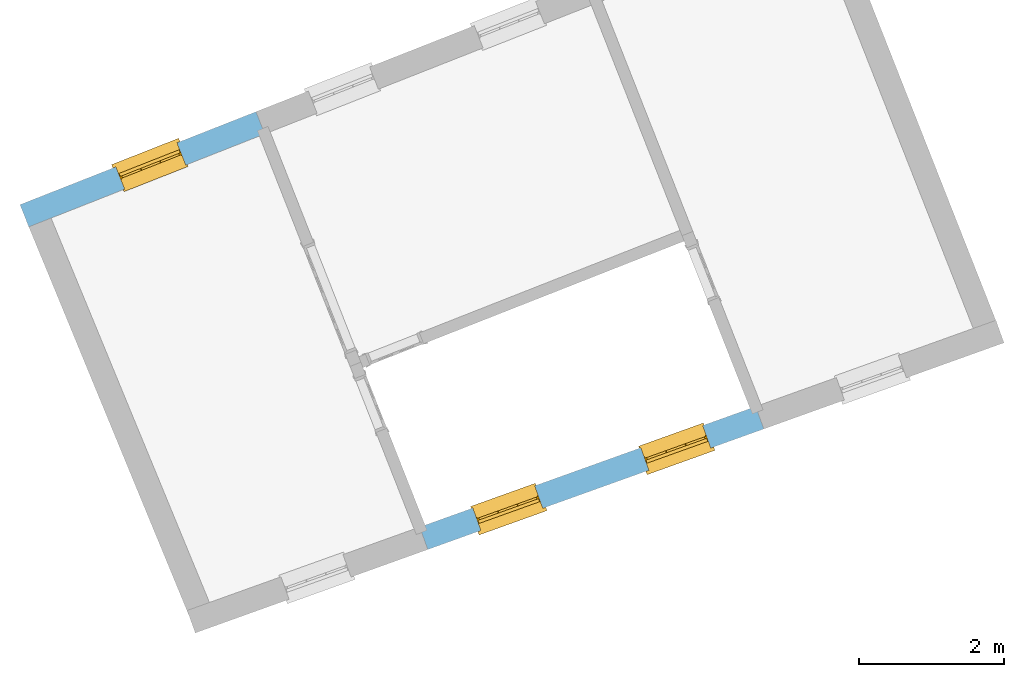
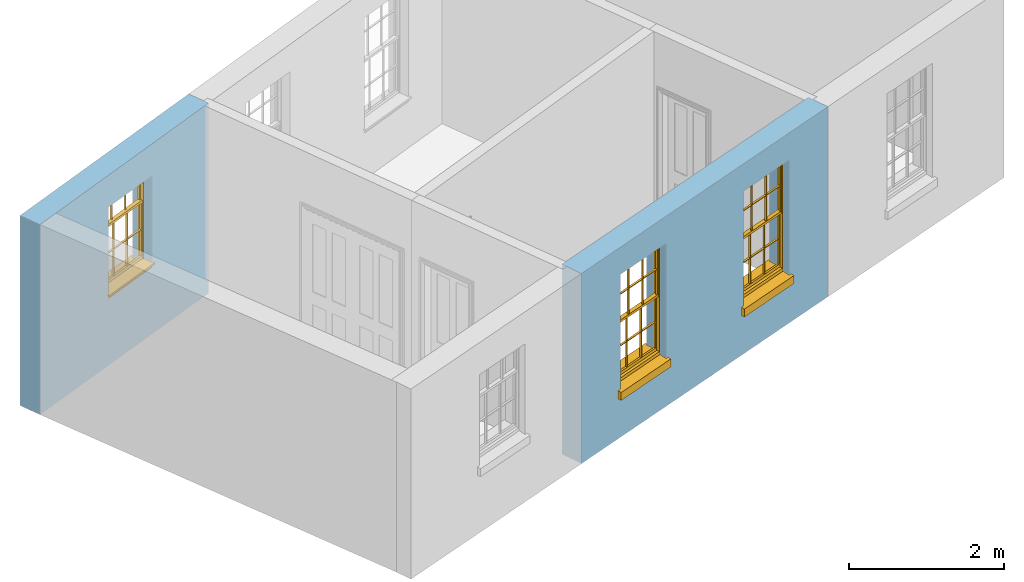
# One storey, part 4 of 6: 3 windows, 3 openings, plus 2 elements that do not belong to this part.
"""IFC2X3 building model written with IfcOpenShell, lengths in metres."""

import ifcopenshell
import ifcopenshell.guid

model = None  # the IFC model being written
_history = None  # IfcOwnerHistory: only IFC2X3 demands one
_inside = {}  # id of a spatial element -> (the spatial element, [elements in it])
_under = {}  # id of a project, library or spatial element -> (it, [spatial elements below it])
_declared = {}  # id of a project -> (the project, [libraries it declares])
_typed = {}  # id of a type object -> (the type object, [elements of that type])
_made_of = {}  # id of a material, layer set ... -> (it, [elements and type objects made of it])


def new_model(schema):
    """Start an empty IFC model of exactly this schema.

    Asked for "IFC4X3", IfcOpenShell would pick the latest addendum, in which some entities
    have other attributes; the version numbers below select the first issue.
    IFC2X3 requires an IfcOwnerHistory on every rooted entity: one is made here for all.
    """
    global model, _history
    if schema == "IFC4X3":
        model = ifcopenshell.file(schema_version=(4, 3, 0, 0))
    else:
        model = ifcopenshell.file(schema=schema)
    _inside.clear()
    _under.clear()
    _declared.clear()
    _typed.clear()
    _made_of.clear()
    _history = None
    if model.schema == "IFC2X3":
        org = make("IfcOrganization", Name="unknown")
        user = make(
            "IfcPersonAndOrganization",
            ThePerson=make("IfcPerson", FamilyName="unknown"),
            TheOrganization=org,
        )
        app = make(
            "IfcApplication",
            ApplicationDeveloper=org,
            Version="unknown",
            ApplicationFullName="unknown",
            ApplicationIdentifier="unknown",
        )
        _history = make(
            "IfcOwnerHistory",
            OwningUser=user,
            OwningApplication=app,
            ChangeAction="ADDED",
            CreationDate=0,
        )
    return model


def make(cls, **values):
    """One entity of the class cls with the attributes given. An attribute that is None is left unset."""
    return model.create_entity(
        cls, **{name: value for name, value in values.items() if value is not None}
    )


def rooted(cls, **values):
    """An entity with a GlobalId (a new one), such as an element, a storey or a relation."""
    return make(cls, GlobalId=ifcopenshell.guid.new(), OwnerHistory=_history, **values)


def si_unit(unit_type, name, prefix=None):
    """IfcSIUnit, for example si_unit("LENGTHUNIT", "METRE", prefix="MILLI")."""
    return make("IfcSIUnit", UnitType=unit_type, Prefix=prefix, Name=name)


def assignment(units):
    """IfcUnitAssignment: the units of a project."""
    return None if units is None else make("IfcUnitAssignment", Units=units)


def point(xyz):
    """IfcCartesianPoint."""
    return None if xyz is None else make("IfcCartesianPoint", Coordinates=xyz)


def direction(xyz):
    """IfcDirection."""
    return None if xyz is None else make("IfcDirection", DirectionRatios=xyz)


def frame(location, z_axis=None, x_axis=None):
    """IfcAxis2Placement3D, a coordinate frame: its origin and axes. An axis left out is left unset."""
    return make(
        "IfcAxis2Placement3D",
        Location=point(location),
        Axis=direction(z_axis),
        RefDirection=direction(x_axis),
    )


def origin():
    """The frame at (0, 0, 0) with its axes left unset."""
    return frame((0.0, 0.0, 0.0))


def place(relative_to, where):
    """IfcLocalPlacement: puts the frame where relative to a parent placement (None: the world)."""
    return make(
        "IfcLocalPlacement", PlacementRelTo=relative_to, RelativePlacement=where
    )


def context(
    kind, dimensions, precision=None, world=None, true_north=None, identifier=None
):
    """IfcGeometricRepresentationContext, for example the 3D "Model" context."""
    return make(
        "IfcGeometricRepresentationContext",
        ContextIdentifier=identifier,
        ContextType=kind,
        CoordinateSpaceDimension=dimensions,
        Precision=precision,
        WorldCoordinateSystem=world,
        TrueNorth=true_north,
    )


def subcontext(parent, identifier, kind, view, scale=None):
    """IfcGeometricRepresentationSubContext, for example "Body" below "Model"."""
    return make(
        "IfcGeometricRepresentationSubContext",
        ContextIdentifier=identifier,
        ContextType=kind,
        ParentContext=parent,
        TargetScale=scale,
        TargetView=view,
    )


def project(units=None, contexts=None):
    """IfcProject with its units and contexts."""
    return rooted(
        "IfcProject",
        Name="project",
        RepresentationContexts=contexts,
        UnitsInContext=assignment(units),
    )


def spatial(cls, under=None, at=None, **own):
    """A site, building, storey or space (cls), placed at a placement, below another one or the project."""
    s = rooted(cls, ObjectPlacement=at, **own)
    if under is not None:
        _under.setdefault(under.id(), (under, []))[1].append(s)
    return s


def polyline(points):
    """IfcPolyline through the points."""
    return make("IfcPolyline", Points=[point(p) for p in points])


def outline(outer, holes=None, kind="AREA"):
    """IfcArbitraryClosedProfileDef: a profile drawn as a closed curve; with holes, ...WithVoids."""
    if holes is None:
        return make("IfcArbitraryClosedProfileDef", ProfileType=kind, OuterCurve=outer)
    return make(
        "IfcArbitraryProfileDefWithVoids",
        ProfileType=kind,
        OuterCurve=outer,
        InnerCurves=holes,
    )


def extrude(swept, where, along, depth):
    """IfcExtrudedAreaSolid: the profile swept, set in the frame where, extruded along a direction by depth."""
    return make(
        "IfcExtrudedAreaSolid",
        SweptArea=swept,
        Position=where,
        ExtrudedDirection=direction(along),
        Depth=depth,
    )


def faces_of(points, faces, orient=None, outer=None):
    """IfcFace entities. A face is a list of loops; a loop is a list of indices into points, from 0.

    orient and outer hold one flag for each loop. By default every Orientation is true, the
    first loop of a face is its IfcFaceOuterBound and the others are IfcFaceBound.
    """
    made = []
    for i, loops in enumerate(faces):
        bounds = []
        for j, loop in enumerate(loops):
            is_outer = j == 0 if outer is None else outer[i][j]
            bounds.append(
                make(
                    "IfcFaceOuterBound" if is_outer else "IfcFaceBound",
                    Bound=make("IfcPolyLoop", Polygon=[points[k] for k in loop]),
                    Orientation=True if orient is None else orient[i][j],
                )
            )
        made.append(make("IfcFace", Bounds=bounds))
    return made


def faceted_brep(points, faces, orient=None, outer=None, voids=None):
    """IfcFacetedBrep: a solid bounded by flat faces; with voids (closed shells), ...WithVoids."""
    shared = [point(p) for p in points]
    hull = make("IfcClosedShell", CfsFaces=faces_of(shared, faces, orient, outer))
    if voids is None:
        return make("IfcFacetedBrep", Outer=hull)
    return make(
        "IfcFacetedBrepWithVoids",
        Outer=hull,
        Voids=[
            make(cls, CfsFaces=faces_of(shared, fs, o, b)) for cls, fs, o, b in voids
        ],
    )


def shape(context_of_items, identifier, shape_type, items):
    """IfcShapeRepresentation: the items that make up one representation, for example the "Body"."""
    return make(
        "IfcShapeRepresentation",
        ContextOfItems=context_of_items,
        RepresentationIdentifier=identifier,
        RepresentationType=shape_type,
        Items=items,
    )


def material(Name=None, Category=None):
    """IfcMaterial."""
    return make("IfcMaterial", Name=Name, Category=Category)


def layer(
    of_material, thickness, ventilated=None, Name=None, Category=None, Priority=None
):
    """IfcMaterialLayer: one layer of a wall or slab, of a material (None: an air gap)."""
    return make(
        "IfcMaterialLayer",
        Material=of_material,
        LayerThickness=thickness,
        IsVentilated=ventilated,
        Name=Name,
        Category=Category,
        Priority=Priority,
    )


def layer_set(layers, Name=None):
    """IfcMaterialLayerSet."""
    return make("IfcMaterialLayerSet", MaterialLayers=layers, LayerSetName=Name)


def layer_usage(for_layer_set, set_direction, sense, offset, extent=None):
    """IfcMaterialLayerSetUsage: how a layer set lies in its element."""
    return make(
        "IfcMaterialLayerSetUsage",
        ForLayerSet=for_layer_set,
        LayerSetDirection=set_direction,
        DirectionSense=sense,
        OffsetFromReferenceLine=offset,
        ReferenceExtent=extent,
    )


def made_of(thing, what):
    """Note that an element or type object is made of a material, layer set ...; save() writes the relation."""
    if what is not None:
        _made_of.setdefault(what.id(), (what, []))[1].append(thing)
    return thing


def element(
    cls,
    number,
    at=None,
    inside=None,
    cuts=None,
    type_object=None,
    material=None,
    context=None,
    identifier="Body",
    shape_type=None,
    held_by="IfcProductDefinitionShape",
    body=None,
    shapes=None,
    **own,
):
    """One element of the class cls, such as IfcWall. Its Tag is "e" and its number.

    at: its placement. inside: the storey or other place that contains it. cuts: it is an
    opening in that element (IfcRelVoidsElement). A single representation is given by context,
    identifier, shape_type and body (its items); several are given by shapes. held_by: the class
    of the entity that holds the representations. save() writes the other relations.
    """
    e = rooted(cls, Tag="e%d" % number, ObjectPlacement=at, **own)
    if body is not None:
        shapes = [shape(context, identifier, shape_type, body)]
    if shapes is not None:
        e.Representation = make(held_by, Representations=shapes)
    if inside is not None:
        _inside.setdefault(inside.id(), (inside, []))[1].append(e)
    if cuts is not None:
        rooted(
            "IfcRelVoidsElement", RelatingBuildingElement=cuts, RelatedOpeningElement=e
        )
    if type_object is not None:
        _typed.setdefault(type_object.id(), (type_object, []))[1].append(e)
    return made_of(e, material)


def fill(opening, filler):
    """IfcRelFillsElement: the door or window that sits in an opening."""
    return rooted(
        "IfcRelFillsElement",
        RelatingOpeningElement=opening,
        RelatedBuildingElement=filler,
    )


def aggregate(whole, parts):
    """IfcRelAggregates: a whole, such as a stair, and the parts it consists of."""
    return rooted("IfcRelAggregates", RelatingObject=whole, RelatedObjects=parts)


def save(model, path):
    """Write the relations noted so far, then the file.

    IfcRelAggregates (storeys below a building ...), IfcRelContainedInSpatialStructure (elements
    in a storey), IfcRelDefinesByType, IfcRelAssociatesMaterial and IfcRelDeclares: one each for
    every whole, place, type object, material and project.
    """
    for whole, parts in _under.values():
        aggregate(whole, parts)
    for where, things in _inside.values():
        rooted(
            "IfcRelContainedInSpatialStructure",
            RelatedElements=things,
            RelatingStructure=where,
        )
    for kind, things in _typed.values():
        rooted("IfcRelDefinesByType", RelatedObjects=things, RelatingType=kind)
    for what, things in _made_of.values():
        rooted("IfcRelAssociatesMaterial", RelatedObjects=things, RelatingMaterial=what)
    for by, libraries in _declared.values():
        rooted("IfcRelDeclares", RelatingContext=by, RelatedDefinitions=libraries)
    model.write(path)


model = new_model("IFC2X3")

# Units and contexts
model_context = context("Model", 3, world=origin())
body_context = subcontext(model_context, "Body", "Model", "MODEL_VIEW")
ifc_project = project(units=[si_unit("PLANEANGLEUNIT", "RADIAN"), si_unit("MASSUNIT", "GRAM", prefix="KILO"), si_unit("FORCEUNIT", "NEWTON", prefix="KILO"), si_unit("LENGTHUNIT", "METRE")], contexts=[model_context])

# Site, building, storey
site_placement = place(None, origin())
site = spatial("IfcSite", under=ifc_project, at=site_placement, CompositionType="ELEMENT")
building_placement = place(None, origin())
building = spatial("IfcBuilding", under=site, at=building_placement, Name="Building plot-4", CompositionType="ELEMENT")
storey_placement = place(None, frame((0.0, 0.0, 6.45)))
storey = spatial("IfcBuildingStorey", under=building, at=storey_placement, Name="Floor 1", CompositionType="ELEMENT", Elevation=6.45)

# Wall, opening, window
ifc_material = material(Name="Masonry")
ifc_layer = layer(ifc_material, 0.33, ventilated=False)
ifc_layer_set = layer_set([ifc_layer], Name="My Wall")
ifc_layer_usage = layer_usage(ifc_layer_set, "AXIS2", "NEGATIVE", 0.08)
wall_1_placement = place(storey_placement, origin())
wall_1 = element("IfcWallStandardCase", 1, at=wall_1_placement, inside=storey, material=ifc_layer_usage, Name="exterior", context=body_context, shape_type="SweptSolid", body=[
    extrude(outline(polyline([(47.4524085148317, 51.9678474183833), (47.3314871355126, 52.2748946786277), (44.0729122767796, 50.9916024381462), (44.1938336560988, 50.6845551779018), (47.4524085148317, 51.9678474183833)])), origin(), (0.0, 0.0, 1.0), 3.0),
])
opening_1_placement = place(storey_placement, frame((0.0, 0.0, 1.05)))
opening_1 = element("IfcOpeningElement", 2, at=opening_1_placement, cuts=wall_1, Name="Opening", ObjectType="Opening", context=body_context, shape_type="SweptSolid", body=[
    extrude(outline(polyline([(46.2418585271816, 51.8457770432509), (45.3951524459018, 51.5123271790678), (45.5160738252209, 51.2052799188234), (46.3627799065008, 51.5387297830065), (46.2418585271816, 51.8457770432509)])), origin(), (0.0, 0.0, 1.0), 1.445),
])
window_1_placement = place(storey_placement, frame((46.3334656327264, 51.6131654824597, 1.05), z_axis=(0.0, 0.0, 1.0), x_axis=(-0.846706081279848, -0.333449864183088, 0.0)))
window_1 = element("IfcWindow", 3, at=window_1_placement, inside=storey, Name="kitchen outside window", OverallHeight=1.445, OverallWidth=0.91, context=body_context, shape_type="Brep", held_by="IfcProductRepresentation", body=[
    faceted_brep([(0.876875, -0.105, 0.999097), (0.876875, -0.105, 1.411875), (0.9, -0.105, 1.435), (0.033125, -0.105, 1.411875), (0.033125, -0.105, 0.999097), (0.01, -0.105, 1.435), (0.033125, -0.135, 1.411875), (0.01, -0.135, 1.435), (0.033125, -0.135, 0.999097), (0.876875, -0.135, 1.411875), (0.876875, -0.135, 0.999097), (0.9, -0.135, 1.435), (0.033125, -0.105, 0.960972), (0.01, -0.105, 0.960972), (0.033125, -0.105, 0.548195), (0.876875, -0.105, 0.960972), (0.876875, -0.105, 0.548195), (0.9, -0.105, 0.960972), (0.876875, -0.105, 0.538195), (0.876875, -0.105, 0.125417), (0.9, -0.105, 0.077167), (0.033125, -0.105, 0.125417), (0.033125, -0.105, 0.538195), (0.01, -0.105, 0.077167), (0.9, -0.135, 0.960972), (0.01, -0.135, 0.960972), (-0.0425, -0.25, 0.01), (-0.0425, -0.3, 0.001667), (0.0, -0.25, 0.01), (0.9525, -0.25, 0.01), (0.91, -0.25, 0.01), (0.9525, -0.3, 0.001667), (-0.02, 0.08, 0.077167), (0.0, 0.08, 0.077167), (-0.02, 0.11, 0.077167), (0.0, -0.06, 0.077167), (0.01, -0.06, 0.077167), (0.91, -0.06, 0.077167), (0.91, 0.08, 0.077167), (0.9, -0.06, 0.077167), (0.93, 0.08, 0.077167), (0.93, 0.11, 0.077167), (0.01, -0.105, 0.999097), (0.01, -0.075, 0.999097), (0.9, -0.105, 0.999097), (0.9, -0.075, 0.999097), (0.876875, -0.075, 0.125417), (0.876875, -0.075, 0.538195), (0.9, -0.075, 0.077167), (0.876875, -0.075, 0.548195), (0.876875, -0.075, 0.960972), (0.033125, -0.075, 0.125417), (0.01, -0.075, 0.077167), (0.033125, -0.075, 0.538195), (0.033125, -0.075, 0.960972), (0.033125, -0.075, 0.548195), (-0.02, 0.08, 0.052167), (-0.02, 0.11, 0.052167), (0.93, 0.11, 0.052167), (0.93, 0.08, 0.052167), (0.91, 0.08, 0.052167), (0.0, 0.08, 0.052167), (0.91, -0.15, 0.026667), (0.0, -0.15, 0.026667), (-0.0425, -0.3, -0.123333), (0.9525, -0.3, -0.123333), (-0.0425, -0.25, -0.123333), (0.9525, -0.25, -0.123333), (0.01, -0.06, 1.435), (0.9, -0.06, 1.435), (0.0, -0.06, 1.445), (0.91, -0.06, 1.445), (0.01, -0.15, 0.077167), (0.9, -0.15, 0.077167), (0.592292, -0.105, 0.125417), (0.592292, -0.075, 0.125417), (0.317708, -0.075, 0.125417), (0.317708, -0.105, 0.125417), (0.592292, -0.105, 0.548195), (0.317708, -0.105, 0.548195), (0.317708, -0.105, 0.538195), (0.592292, -0.105, 0.538195), (0.592292, -0.075, 0.548195), (0.317708, -0.075, 0.548195), (0.602292, -0.075, 0.548195), (0.602292, -0.105, 0.548195), (0.317708, -0.075, 0.538195), (0.307708, -0.075, 0.125417), (0.307708, -0.075, 0.538195), (0.602292, -0.075, 0.538195), (0.602292, -0.075, 0.125417), (0.592292, -0.075, 0.538195), (0.307708, -0.075, 0.548195), (0.317708, -0.075, 0.960972), (0.307708, -0.075, 0.960972), (0.602292, -0.075, 0.960972), (0.592292, -0.075, 0.960972), (0.307708, -0.105, 0.538195), (0.307708, -0.105, 0.125417), (0.307708, -0.105, 0.548195), (0.307708, -0.105, 0.960972), (0.592292, -0.105, 0.960972), (0.317708, -0.105, 0.960972), (0.602292, -0.105, 0.960972), (0.602292, -0.105, 0.538195), (0.602292, -0.105, 0.125417), (0.317708, -0.135, 1.411875), (0.307708, -0.135, 1.411875), (0.307708, -0.135, 0.999097), (0.317708, -0.135, 0.999097), (0.602292, -0.135, 1.411875), (0.592292, -0.135, 1.411875), (0.592292, -0.135, 0.999097), (0.602292, -0.135, 0.999097), (0.317708, -0.105, 0.999097), (0.307708, -0.105, 0.999097), (0.307708, -0.105, 1.411875), (0.317708, -0.105, 1.411875), (0.602292, -0.105, 0.999097), (0.592292, -0.105, 0.999097), (0.592292, -0.105, 1.411875), (0.602292, -0.105, 1.411875), (0.91, -0.15, 1.445), (0.9, -0.15, 1.435), (0.01, -0.15, 1.435), (0.0, -0.15, 1.445), (0.91, -0.25, 0.0), (0.0, -0.25, 0.0), (0.91, 0.08, 0.0), (0.0, 0.08, 0.0)], [[[0, 1, 2]], [[3, 4, 5]], [[6, 7, 8]], [[9, 10, 11]], [[12, 13, 14]], [[15, 16, 17]], [[18, 19, 20]], [[21, 22, 23]], [[24, 15, 17]], [[13, 12, 25]], [[26, 27, 28]], [[29, 30, 31]], [[32, 33, 34]], [[35, 36, 33]], [[37, 38, 39]], [[40, 41, 38]], [[42, 4, 43]], [[44, 45, 0]], [[46, 47, 48]], [[49, 50, 45]], [[51, 52, 53]], [[54, 55, 43]], [[38, 33, 36, 39]], [[41, 34, 33, 38]], [[56, 32, 34, 57]], [[57, 34, 41, 58]], [[58, 41, 40, 59]], [[57, 58, 60, 61]], [[52, 48, 39, 36]], [[62, 63, 28, 30]], [[27, 31, 30, 28]], [[27, 64, 65, 31]], [[66, 67, 65, 64]], [[2, 5, 68, 69]], [[68, 70, 71, 69]], [[20, 23, 72, 73]], [[73, 72, 63, 62]], [[74, 75, 76, 77]], [[78, 79, 80, 81]], [[78, 82, 83, 79]], [[16, 49, 84, 85]], [[86, 76, 87, 88]], [[89, 90, 75, 91]], [[92, 88, 53, 55]], [[82, 91, 86, 83]], [[93, 83, 92, 94]], [[95, 84, 82, 96]], [[89, 84, 49, 47]], [[97, 88, 87, 98]], [[22, 53, 88, 97]], [[81, 91, 75, 74]], [[80, 86, 91, 81]], [[77, 76, 86, 80]], [[99, 92, 55, 14]], [[100, 94, 92, 99]], [[101, 96, 82, 78]], [[79, 83, 93, 102]], [[85, 84, 95, 103]], [[104, 89, 47, 18]], [[105, 90, 89, 104]], [[104, 18, 16, 85]], [[80, 97, 98, 77]], [[104, 81, 74, 105]], [[103, 101, 78, 85]], [[99, 14, 22, 97]], [[102, 100, 99, 79]], [[106, 107, 108, 109]], [[110, 111, 112, 113]], [[114, 115, 116, 117]], [[118, 119, 120, 121]], [[107, 116, 115, 108]], [[111, 120, 119, 112]], [[109, 114, 117, 106]], [[113, 118, 121, 110]], [[85, 78, 81, 104]], [[84, 89, 91, 82]], [[83, 86, 88, 92]], [[79, 99, 97, 80]], [[109, 112, 119, 114]], [[102, 93, 96, 101]], [[106, 117, 120, 111]], [[98, 87, 51, 21]], [[6, 3, 116, 107]], [[110, 121, 1, 9]], [[19, 46, 90, 105]], [[26, 66, 64, 27]], [[29, 31, 65, 67]], [[25, 24, 112, 109]], [[11, 7, 106, 111]], [[75, 48, 52, 76]], [[43, 45, 96, 93]], [[45, 43, 114, 119]], [[5, 2, 120, 117]], [[24, 25, 102, 101]], [[42, 5, 4]], [[2, 44, 0]], [[49, 45, 48, 47]], [[52, 43, 55, 53]], [[14, 13, 23, 22]], [[20, 17, 16, 18]], [[24, 11, 10]], [[25, 8, 7]], [[8, 4, 3, 6]], [[9, 1, 0, 10]], [[15, 50, 49, 16]], [[18, 47, 46, 19]], [[21, 51, 53, 22]], [[14, 55, 54, 12]], [[44, 2, 69, 45]], [[68, 5, 42, 43]], [[36, 35, 70, 68]], [[39, 69, 71, 37]], [[62, 122, 123, 73]], [[63, 72, 124, 125]], [[8, 108, 115, 4]], [[113, 10, 0, 118]], [[94, 100, 12, 54]], [[17, 20, 73, 24]], [[72, 23, 13, 25]], [[52, 36, 68, 43]], [[69, 39, 48, 45]], [[11, 24, 73, 123]], [[7, 124, 72, 25]], [[23, 77, 98]], [[98, 21, 23]], [[105, 74, 20]], [[20, 19, 105]], [[20, 74, 77, 23]], [[113, 112, 24]], [[24, 10, 113]], [[25, 109, 108]], [[108, 8, 25]], [[110, 9, 11]], [[11, 111, 110]], [[7, 6, 107]], [[107, 106, 7]], [[5, 117, 116]], [[116, 3, 5]], [[121, 120, 2]], [[2, 1, 121]], [[11, 123, 124, 7]], [[122, 125, 124, 123]], [[43, 93, 94]], [[94, 54, 43]], [[96, 45, 95]], [[50, 95, 45]], [[15, 103, 95, 50]], [[48, 75, 90]], [[90, 46, 48]], [[87, 76, 52]], [[52, 51, 87]], [[103, 15, 24]], [[24, 101, 103]], [[100, 102, 25]], [[25, 12, 100]], [[115, 114, 43]], [[43, 4, 115]], [[118, 0, 45]], [[45, 119, 118]], [[71, 70, 125, 122]], [[70, 35, 63, 125]], [[122, 62, 37, 71]], [[126, 67, 66, 127]], [[60, 58, 59]], [[38, 60, 59, 40]], [[61, 56, 57]], [[32, 56, 61, 33]], [[61, 60, 128, 129]], [[62, 60, 38, 37]], [[126, 128, 60, 62]], [[33, 61, 63, 35]], [[61, 129, 127, 63]], [[128, 126, 127, 129]], [[28, 127, 66, 26]], [[63, 127, 28]], [[29, 67, 126, 30]], [[30, 126, 62]]]),
])
fill(opening_1, window_1)

# Wall, openings, windows
wall_2_placement = place(storey_placement, origin())
wall_2 = element("IfcWallStandardCase", 4, at=wall_2_placement, inside=storey, material=ifc_layer_usage, Name="exterior", context=body_context, shape_type="SweptSolid", body=[
    extrude(outline(polyline([(49.5927970052436, 46.539607653732), (49.70423854185, 46.2289940933087), (54.3439530966588, 47.8936249571326), (54.2325115600524, 48.2042385175559), (49.5927970052436, 46.539607653732)])), origin(), (0.0, 0.0, 1.0), 3.0),
])
opening_2_placement = place(storey_placement, frame((0.0, 0.0, 0.75)))
opening_2 = element("IfcOpeningElement", 5, at=opening_2_placement, cuts=wall_2, Name="Opening", ObjectType="Opening", context=body_context, shape_type="SweptSolid", body=[
    extrude(outline(polyline([(50.4358969684534, 46.4914975693984), (51.2924373926509, 46.7988060491311), (51.1809958560445, 47.1094196095543), (50.3244554318471, 46.8021111298216), (50.4358969684534, 46.4914975693984)])), origin(), (0.0, 0.0, 1.0), 1.82),
])
opening_3_placement = place(storey_placement, frame((0.0, 0.0, 0.75)))
opening_3 = element("IfcOpeningElement", 6, at=opening_3_placement, cuts=wall_2, Name="Opening", ObjectType="Opening", context=body_context, shape_type="SweptSolid", body=[
    extrude(outline(polyline([(52.7557542458578, 47.3238130013103), (53.6122946700553, 47.631121481043), (53.5008531334489, 47.9417350414663), (52.6443127092515, 47.6344265617336), (52.7557542458578, 47.3238130013103)])), origin(), (0.0, 0.0, 1.0), 1.82),
])
window_2_placement = place(storey_placement, frame((50.3514715619335, 46.7268108727493, 0.75), z_axis=(0.0, 0.0, 1.0), x_axis=(0.856540424197469, 0.307308479732683, 0.0)))
window_2 = element("IfcWindow", 7, at=window_2_placement, inside=storey, Name="circulation outside window", OverallHeight=1.82, OverallWidth=0.91, context=body_context, shape_type="Brep", held_by="IfcProductRepresentation", body=[
    faceted_brep([(0.033125, -0.105, 0.975209), (0.01, -0.105, 0.975209), (0.033125, -0.105, 1.376042), (0.876875, -0.105, 0.975209), (0.876875, -0.105, 1.376042), (0.9, -0.105, 0.975209), (0.876875, -0.105, 1.386042), (0.876875, -0.105, 1.786875), (0.9, -0.105, 1.81), (0.033125, -0.105, 1.786875), (0.033125, -0.105, 1.386042), (0.01, -0.105, 1.81), (0.876875, -0.135, 1.376042), (0.876875, -0.135, 0.975209), (0.9, -0.135, 0.937083), (0.033125, -0.135, 1.786875), (0.01, -0.135, 1.81), (0.033125, -0.135, 1.386042), (0.01, -0.135, 0.937083), (0.033125, -0.135, 0.975209), (0.033125, -0.135, 1.376042), (0.876875, -0.135, 1.786875), (0.876875, -0.135, 1.386042), (0.9, -0.135, 1.81), (0.033125, -0.105, 0.937083), (0.01, -0.105, 0.937083), (0.033125, -0.105, 0.53625), (0.876875, -0.105, 0.937083), (0.876875, -0.105, 0.53625), (0.9, -0.105, 0.937083), (0.876875, -0.105, 0.52625), (0.876875, -0.105, 0.125417), (0.9, -0.105, 0.077167), (0.033125, -0.105, 0.125417), (0.033125, -0.105, 0.52625), (0.01, -0.105, 0.077167), (-0.0425, -0.25, 0.01), (-0.0425, -0.3, 0.001667), (0.0, -0.25, 0.01), (0.9525, -0.25, 0.01), (0.91, -0.25, 0.01), (0.9525, -0.3, 0.001667), (-0.02, 0.08, 0.077167), (0.0, 0.08, 0.077167), (-0.02, 0.11, 0.077167), (0.0, -0.06, 0.077167), (0.01, -0.06, 0.077167), (0.91, -0.06, 0.077167), (0.91, 0.08, 0.077167), (0.9, -0.06, 0.077167), (0.93, 0.08, 0.077167), (0.93, 0.11, 0.077167), (0.01, -0.075, 0.975209), (0.9, -0.075, 0.975209), (0.876875, -0.075, 0.125417), (0.876875, -0.075, 0.52625), (0.9, -0.075, 0.077167), (0.876875, -0.075, 0.53625), (0.876875, -0.075, 0.937083), (0.033125, -0.075, 0.125417), (0.01, -0.075, 0.077167), (0.033125, -0.075, 0.52625), (0.033125, -0.075, 0.937083), (0.033125, -0.075, 0.53625), (-0.02, 0.08, 0.052167), (-0.02, 0.11, 0.052167), (0.93, 0.11, 0.052167), (0.93, 0.08, 0.052167), (0.91, 0.08, 0.052167), (0.0, 0.08, 0.052167), (0.91, -0.15, 0.026667), (0.0, -0.15, 0.026667), (-0.0425, -0.3, -0.123333), (0.9525, -0.3, -0.123333), (-0.0425, -0.25, -0.123333), (0.9525, -0.25, -0.123333), (0.01, -0.06, 1.81), (0.9, -0.06, 1.81), (0.0, -0.06, 1.82), (0.91, -0.06, 1.82), (0.01, -0.15, 0.077167), (0.9, -0.15, 0.077167), (0.592292, -0.105, 0.125417), (0.592292, -0.075, 0.125417), (0.317708, -0.075, 0.125417), (0.317708, -0.105, 0.125417), (0.592292, -0.105, 0.53625), (0.317708, -0.105, 0.53625), (0.317708, -0.105, 0.52625), (0.592292, -0.105, 0.52625), (0.592292, -0.075, 0.53625), (0.317708, -0.075, 0.53625), (0.592292, -0.135, 1.386042), (0.592292, -0.105, 1.386042), (0.317708, -0.105, 1.386042), (0.317708, -0.135, 1.386042), (0.317708, -0.135, 1.376042), (0.592292, -0.135, 1.376042), (0.317708, -0.105, 1.376042), (0.592292, -0.105, 1.376042), (0.602292, -0.135, 1.376042), (0.592292, -0.135, 0.975209), (0.602292, -0.135, 0.975209), (0.602292, -0.105, 0.975209), (0.592292, -0.105, 0.975209), (0.602292, -0.105, 1.376042), (0.602292, -0.075, 0.53625), (0.602292, -0.105, 0.53625), (0.317708, -0.075, 0.52625), (0.307708, -0.075, 0.125417), (0.307708, -0.075, 0.52625), (0.602292, -0.075, 0.52625), (0.602292, -0.075, 0.125417), (0.592292, -0.075, 0.52625), (0.307708, -0.075, 0.53625), (0.317708, -0.075, 0.937083), (0.307708, -0.075, 0.937083), (0.602292, -0.075, 0.937083), (0.592292, -0.075, 0.937083), (0.307708, -0.105, 0.52625), (0.307708, -0.105, 0.125417), (0.307708, -0.105, 0.53625), (0.307708, -0.105, 0.937083), (0.592292, -0.105, 0.937083), (0.317708, -0.105, 0.937083), (0.602292, -0.105, 0.937083), (0.602292, -0.105, 0.52625), (0.602292, -0.105, 0.125417), (0.307708, -0.135, 1.386042), (0.307708, -0.135, 1.376042), (0.307708, -0.135, 0.975209), (0.317708, -0.135, 0.975209), (0.317708, -0.135, 1.786875), (0.307708, -0.135, 1.786875), (0.602292, -0.135, 1.786875), (0.592292, -0.135, 1.786875), (0.602292, -0.135, 1.386042), (0.602292, -0.105, 1.386042), (0.307708, -0.105, 1.386042), (0.307708, -0.105, 1.786875), (0.317708, -0.105, 1.786875), (0.592292, -0.105, 1.786875), (0.602292, -0.105, 1.786875), (0.307708, -0.105, 1.376042), (0.317708, -0.105, 0.975209), (0.307708, -0.105, 0.975209), (0.91, -0.15, 1.82), (0.9, -0.15, 1.81), (0.01, -0.15, 1.81), (0.0, -0.15, 1.82), (0.91, -0.25, 0.0), (0.0, -0.25, 0.0), (0.91, 0.08, 0.0), (0.0, 0.08, 0.0)], [[[0, 1, 2]], [[3, 4, 5]], [[6, 7, 8]], [[9, 10, 11]], [[12, 13, 14]], [[15, 16, 17]], [[18, 19, 20]], [[21, 22, 23]], [[24, 25, 26]], [[27, 28, 29]], [[30, 31, 32]], [[33, 34, 35]], [[14, 27, 29]], [[25, 24, 18]], [[36, 37, 38]], [[39, 40, 41]], [[42, 43, 44]], [[45, 46, 43]], [[47, 48, 49]], [[50, 51, 48]], [[1, 0, 52]], [[5, 53, 3]], [[54, 55, 56]], [[57, 58, 53]], [[59, 60, 61]], [[62, 63, 52]], [[48, 43, 46, 49]], [[51, 44, 43, 48]], [[64, 42, 44, 65]], [[65, 44, 51, 66]], [[66, 51, 50, 67]], [[65, 66, 68, 69]], [[60, 56, 49, 46]], [[70, 71, 38, 40]], [[37, 41, 40, 38]], [[37, 72, 73, 41]], [[74, 75, 73, 72]], [[8, 11, 76, 77]], [[76, 78, 79, 77]], [[32, 35, 80, 81]], [[81, 80, 71, 70]], [[82, 83, 84, 85]], [[86, 87, 88, 89]], [[86, 90, 91, 87]], [[92, 93, 94, 95]], [[92, 95, 96, 97]], [[96, 98, 99, 97]], [[100, 97, 101, 102]], [[103, 104, 99, 105]], [[97, 99, 104, 101]], [[102, 103, 105, 100]], [[28, 57, 106, 107]], [[108, 84, 109, 110]], [[111, 112, 83, 113]], [[114, 110, 61, 63]], [[90, 113, 108, 91]], [[115, 91, 114, 116]], [[117, 106, 90, 118]], [[111, 106, 57, 55]], [[119, 110, 109, 120]], [[34, 61, 110, 119]], [[89, 113, 83, 82]], [[88, 108, 113, 89]], [[85, 84, 108, 88]], [[121, 114, 63, 26]], [[122, 116, 114, 121]], [[123, 118, 90, 86]], [[87, 91, 115, 124]], [[107, 106, 117, 125]], [[126, 111, 55, 30]], [[127, 112, 111, 126]], [[126, 30, 28, 107]], [[88, 119, 120, 85]], [[126, 89, 82, 127]], [[125, 123, 86, 107]], [[121, 26, 34, 119]], [[124, 122, 121, 87]], [[128, 17, 20, 129]], [[96, 129, 130, 131]], [[132, 133, 128, 95]], [[134, 135, 92, 136]], [[100, 12, 22, 136]], [[137, 6, 4, 105]], [[94, 138, 139, 140]], [[137, 93, 141, 142]], [[99, 98, 94, 93]], [[143, 2, 10, 138]], [[144, 145, 143, 98]], [[129, 143, 145, 130]], [[20, 2, 143, 129]], [[131, 144, 98, 96]], [[128, 138, 10, 17]], [[133, 139, 138, 128]], [[135, 141, 93, 92]], [[95, 94, 140, 132]], [[22, 6, 137, 136]], [[136, 137, 142, 134]], [[100, 105, 4, 12]], [[107, 86, 89, 126]], [[106, 111, 113, 90]], [[91, 108, 110, 114]], [[87, 121, 119, 88]], [[97, 100, 136, 92]], [[129, 96, 95, 128]], [[98, 143, 138, 94]], [[105, 99, 93, 137]], [[131, 101, 104, 144]], [[124, 115, 118, 123]], [[132, 140, 141, 135]], [[120, 109, 59, 33]], [[15, 9, 139, 133]], [[134, 142, 7, 21]], [[31, 54, 112, 127]], [[36, 74, 72, 37]], [[39, 41, 73, 75]], [[18, 14, 101, 131]], [[23, 16, 132, 135]], [[83, 56, 60, 84]], [[52, 53, 118, 115]], [[53, 52, 144, 104]], [[11, 8, 141, 140]], [[14, 18, 124, 123]], [[2, 1, 11, 10]], [[8, 5, 4, 6]], [[57, 53, 56, 55]], [[60, 52, 63, 61]], [[26, 25, 35, 34]], [[32, 29, 28, 30]], [[14, 23, 22, 12]], [[18, 20, 17, 16]], [[19, 0, 2, 20]], [[17, 10, 9, 15]], [[12, 4, 3, 13]], [[21, 7, 6, 22]], [[27, 58, 57, 28]], [[30, 55, 54, 31]], [[33, 59, 61, 34]], [[26, 63, 62, 24]], [[5, 8, 77, 53]], [[76, 11, 1, 52]], [[46, 45, 78, 76]], [[49, 77, 79, 47]], [[70, 146, 147, 81]], [[71, 80, 148, 149]], [[19, 130, 145, 0]], [[102, 13, 3, 103]], [[116, 122, 24, 62]], [[29, 32, 81, 14]], [[80, 35, 25, 18]], [[60, 46, 76, 52]], [[77, 49, 56, 53]], [[23, 14, 81, 147]], [[16, 148, 80, 18]], [[35, 85, 120]], [[120, 33, 35]], [[127, 82, 32]], [[32, 31, 127]], [[32, 82, 85, 35]], [[102, 101, 14]], [[14, 13, 102]], [[18, 131, 130]], [[130, 19, 18]], [[134, 21, 23]], [[23, 135, 134]], [[16, 15, 133]], [[133, 132, 16]], [[11, 140, 139]], [[139, 9, 11]], [[142, 141, 8]], [[8, 7, 142]], [[23, 147, 148, 16]], [[146, 149, 148, 147]], [[52, 115, 116]], [[116, 62, 52]], [[118, 53, 117]], [[58, 117, 53]], [[27, 125, 117, 58]], [[56, 83, 112]], [[112, 54, 56]], [[109, 84, 60]], [[60, 59, 109]], [[125, 27, 14]], [[14, 123, 125]], [[122, 124, 18]], [[18, 24, 122]], [[145, 144, 52]], [[52, 0, 145]], [[103, 3, 53]], [[53, 104, 103]], [[79, 78, 149, 146]], [[78, 45, 71, 149]], [[146, 70, 47, 79]], [[150, 75, 74, 151]], [[68, 66, 67]], [[48, 68, 67, 50]], [[69, 64, 65]], [[42, 64, 69, 43]], [[69, 68, 152, 153]], [[70, 68, 48, 47]], [[150, 152, 68, 70]], [[43, 69, 71, 45]], [[69, 153, 151, 71]], [[152, 150, 151, 153]], [[38, 151, 74, 36]], [[71, 151, 38]], [[39, 75, 150, 40]], [[40, 150, 70]]]),
])
fill(opening_2, window_2)
window_3_placement = place(storey_placement, frame((52.6713288393379, 47.5591263046613, 0.75), z_axis=(0.0, 0.0, 1.0), x_axis=(0.856540424197469, 0.307308479732697, 0.0)))
window_3 = element("IfcWindow", 8, at=window_3_placement, inside=storey, Name="circulation outside window", OverallHeight=1.82, OverallWidth=0.91, context=body_context, shape_type="Brep", held_by="IfcProductRepresentation", body=[
    faceted_brep([(0.033125, -0.105, 0.975209), (0.01, -0.105, 0.975209), (0.033125, -0.105, 1.376042), (0.876875, -0.105, 0.975209), (0.876875, -0.105, 1.376042), (0.9, -0.105, 0.975209), (0.876875, -0.105, 1.386042), (0.876875, -0.105, 1.786875), (0.9, -0.105, 1.81), (0.033125, -0.105, 1.786875), (0.033125, -0.105, 1.386042), (0.01, -0.105, 1.81), (0.876875, -0.135, 1.376042), (0.876875, -0.135, 0.975209), (0.9, -0.135, 0.937083), (0.033125, -0.135, 1.786875), (0.01, -0.135, 1.81), (0.033125, -0.135, 1.386042), (0.01, -0.135, 0.937083), (0.033125, -0.135, 0.975209), (0.033125, -0.135, 1.376042), (0.876875, -0.135, 1.786875), (0.876875, -0.135, 1.386042), (0.9, -0.135, 1.81), (0.033125, -0.105, 0.937083), (0.01, -0.105, 0.937083), (0.033125, -0.105, 0.53625), (0.876875, -0.105, 0.937083), (0.876875, -0.105, 0.53625), (0.9, -0.105, 0.937083), (0.876875, -0.105, 0.52625), (0.876875, -0.105, 0.125417), (0.9, -0.105, 0.077167), (0.033125, -0.105, 0.125417), (0.033125, -0.105, 0.52625), (0.01, -0.105, 0.077167), (-0.0425, -0.25, 0.01), (-0.0425, -0.3, 0.001667), (0.0, -0.25, 0.01), (0.9525, -0.25, 0.01), (0.91, -0.25, 0.01), (0.9525, -0.3, 0.001667), (-0.02, 0.08, 0.077167), (0.0, 0.08, 0.077167), (-0.02, 0.11, 0.077167), (0.0, -0.06, 0.077167), (0.01, -0.06, 0.077167), (0.91, -0.06, 0.077167), (0.91, 0.08, 0.077167), (0.9, -0.06, 0.077167), (0.93, 0.08, 0.077167), (0.93, 0.11, 0.077167), (0.01, -0.075, 0.975209), (0.9, -0.075, 0.975209), (0.876875, -0.075, 0.125417), (0.876875, -0.075, 0.52625), (0.9, -0.075, 0.077167), (0.876875, -0.075, 0.53625), (0.876875, -0.075, 0.937083), (0.033125, -0.075, 0.125417), (0.01, -0.075, 0.077167), (0.033125, -0.075, 0.52625), (0.033125, -0.075, 0.937083), (0.033125, -0.075, 0.53625), (-0.02, 0.08, 0.052167), (-0.02, 0.11, 0.052167), (0.93, 0.11, 0.052167), (0.93, 0.08, 0.052167), (0.91, 0.08, 0.052167), (0.0, 0.08, 0.052167), (0.91, -0.15, 0.026667), (0.0, -0.15, 0.026667), (-0.0425, -0.3, -0.123333), (0.9525, -0.3, -0.123333), (-0.0425, -0.25, -0.123333), (0.9525, -0.25, -0.123333), (0.01, -0.06, 1.81), (0.9, -0.06, 1.81), (0.0, -0.06, 1.82), (0.91, -0.06, 1.82), (0.01, -0.15, 0.077167), (0.9, -0.15, 0.077167), (0.592292, -0.105, 0.125417), (0.592292, -0.075, 0.125417), (0.317708, -0.075, 0.125417), (0.317708, -0.105, 0.125417), (0.592292, -0.105, 0.53625), (0.317708, -0.105, 0.53625), (0.317708, -0.105, 0.52625), (0.592292, -0.105, 0.52625), (0.592292, -0.075, 0.53625), (0.317708, -0.075, 0.53625), (0.592292, -0.135, 1.386042), (0.592292, -0.105, 1.386042), (0.317708, -0.105, 1.386042), (0.317708, -0.135, 1.386042), (0.317708, -0.135, 1.376042), (0.592292, -0.135, 1.376042), (0.317708, -0.105, 1.376042), (0.592292, -0.105, 1.376042), (0.602292, -0.135, 1.376042), (0.592292, -0.135, 0.975209), (0.602292, -0.135, 0.975209), (0.602292, -0.105, 0.975209), (0.592292, -0.105, 0.975209), (0.602292, -0.105, 1.376042), (0.602292, -0.075, 0.53625), (0.602292, -0.105, 0.53625), (0.317708, -0.075, 0.52625), (0.307708, -0.075, 0.125417), (0.307708, -0.075, 0.52625), (0.602292, -0.075, 0.52625), (0.602292, -0.075, 0.125417), (0.592292, -0.075, 0.52625), (0.307708, -0.075, 0.53625), (0.317708, -0.075, 0.937083), (0.307708, -0.075, 0.937083), (0.602292, -0.075, 0.937083), (0.592292, -0.075, 0.937083), (0.307708, -0.105, 0.52625), (0.307708, -0.105, 0.125417), (0.307708, -0.105, 0.53625), (0.307708, -0.105, 0.937083), (0.592292, -0.105, 0.937083), (0.317708, -0.105, 0.937083), (0.602292, -0.105, 0.937083), (0.602292, -0.105, 0.52625), (0.602292, -0.105, 0.125417), (0.307708, -0.135, 1.386042), (0.307708, -0.135, 1.376042), (0.307708, -0.135, 0.975209), (0.317708, -0.135, 0.975209), (0.317708, -0.135, 1.786875), (0.307708, -0.135, 1.786875), (0.602292, -0.135, 1.786875), (0.592292, -0.135, 1.786875), (0.602292, -0.135, 1.386042), (0.602292, -0.105, 1.386042), (0.307708, -0.105, 1.386042), (0.307708, -0.105, 1.786875), (0.317708, -0.105, 1.786875), (0.592292, -0.105, 1.786875), (0.602292, -0.105, 1.786875), (0.307708, -0.105, 1.376042), (0.317708, -0.105, 0.975209), (0.307708, -0.105, 0.975209), (0.91, -0.15, 1.82), (0.9, -0.15, 1.81), (0.01, -0.15, 1.81), (0.0, -0.15, 1.82), (0.91, -0.25, 0.0), (0.0, -0.25, 0.0), (0.91, 0.08, 0.0), (0.0, 0.08, 0.0)], [[[0, 1, 2]], [[3, 4, 5]], [[6, 7, 8]], [[9, 10, 11]], [[12, 13, 14]], [[15, 16, 17]], [[18, 19, 20]], [[21, 22, 23]], [[24, 25, 26]], [[27, 28, 29]], [[30, 31, 32]], [[33, 34, 35]], [[14, 27, 29]], [[25, 24, 18]], [[36, 37, 38]], [[39, 40, 41]], [[42, 43, 44]], [[45, 46, 43]], [[47, 48, 49]], [[50, 51, 48]], [[1, 0, 52]], [[5, 53, 3]], [[54, 55, 56]], [[57, 58, 53]], [[59, 60, 61]], [[62, 63, 52]], [[48, 43, 46, 49]], [[51, 44, 43, 48]], [[64, 42, 44, 65]], [[65, 44, 51, 66]], [[66, 51, 50, 67]], [[65, 66, 68, 69]], [[60, 56, 49, 46]], [[70, 71, 38, 40]], [[37, 41, 40, 38]], [[37, 72, 73, 41]], [[74, 75, 73, 72]], [[8, 11, 76, 77]], [[76, 78, 79, 77]], [[32, 35, 80, 81]], [[81, 80, 71, 70]], [[82, 83, 84, 85]], [[86, 87, 88, 89]], [[86, 90, 91, 87]], [[92, 93, 94, 95]], [[92, 95, 96, 97]], [[96, 98, 99, 97]], [[100, 97, 101, 102]], [[103, 104, 99, 105]], [[97, 99, 104, 101]], [[102, 103, 105, 100]], [[28, 57, 106, 107]], [[108, 84, 109, 110]], [[111, 112, 83, 113]], [[114, 110, 61, 63]], [[90, 113, 108, 91]], [[115, 91, 114, 116]], [[117, 106, 90, 118]], [[111, 106, 57, 55]], [[119, 110, 109, 120]], [[34, 61, 110, 119]], [[89, 113, 83, 82]], [[88, 108, 113, 89]], [[85, 84, 108, 88]], [[121, 114, 63, 26]], [[122, 116, 114, 121]], [[123, 118, 90, 86]], [[87, 91, 115, 124]], [[107, 106, 117, 125]], [[126, 111, 55, 30]], [[127, 112, 111, 126]], [[126, 30, 28, 107]], [[88, 119, 120, 85]], [[126, 89, 82, 127]], [[125, 123, 86, 107]], [[121, 26, 34, 119]], [[124, 122, 121, 87]], [[128, 17, 20, 129]], [[96, 129, 130, 131]], [[132, 133, 128, 95]], [[134, 135, 92, 136]], [[100, 12, 22, 136]], [[137, 6, 4, 105]], [[94, 138, 139, 140]], [[137, 93, 141, 142]], [[99, 98, 94, 93]], [[143, 2, 10, 138]], [[144, 145, 143, 98]], [[129, 143, 145, 130]], [[20, 2, 143, 129]], [[131, 144, 98, 96]], [[128, 138, 10, 17]], [[133, 139, 138, 128]], [[135, 141, 93, 92]], [[95, 94, 140, 132]], [[22, 6, 137, 136]], [[136, 137, 142, 134]], [[100, 105, 4, 12]], [[107, 86, 89, 126]], [[106, 111, 113, 90]], [[91, 108, 110, 114]], [[87, 121, 119, 88]], [[97, 100, 136, 92]], [[129, 96, 95, 128]], [[98, 143, 138, 94]], [[105, 99, 93, 137]], [[131, 101, 104, 144]], [[124, 115, 118, 123]], [[132, 140, 141, 135]], [[120, 109, 59, 33]], [[15, 9, 139, 133]], [[134, 142, 7, 21]], [[31, 54, 112, 127]], [[36, 74, 72, 37]], [[39, 41, 73, 75]], [[18, 14, 101, 131]], [[23, 16, 132, 135]], [[83, 56, 60, 84]], [[52, 53, 118, 115]], [[53, 52, 144, 104]], [[11, 8, 141, 140]], [[14, 18, 124, 123]], [[2, 1, 11, 10]], [[8, 5, 4, 6]], [[57, 53, 56, 55]], [[60, 52, 63, 61]], [[26, 25, 35, 34]], [[32, 29, 28, 30]], [[14, 23, 22, 12]], [[18, 20, 17, 16]], [[19, 0, 2, 20]], [[17, 10, 9, 15]], [[12, 4, 3, 13]], [[21, 7, 6, 22]], [[27, 58, 57, 28]], [[30, 55, 54, 31]], [[33, 59, 61, 34]], [[26, 63, 62, 24]], [[5, 8, 77, 53]], [[76, 11, 1, 52]], [[46, 45, 78, 76]], [[49, 77, 79, 47]], [[70, 146, 147, 81]], [[71, 80, 148, 149]], [[19, 130, 145, 0]], [[102, 13, 3, 103]], [[116, 122, 24, 62]], [[29, 32, 81, 14]], [[80, 35, 25, 18]], [[60, 46, 76, 52]], [[77, 49, 56, 53]], [[23, 14, 81, 147]], [[16, 148, 80, 18]], [[35, 85, 120]], [[120, 33, 35]], [[127, 82, 32]], [[32, 31, 127]], [[32, 82, 85, 35]], [[102, 101, 14]], [[14, 13, 102]], [[18, 131, 130]], [[130, 19, 18]], [[134, 21, 23]], [[23, 135, 134]], [[16, 15, 133]], [[133, 132, 16]], [[11, 140, 139]], [[139, 9, 11]], [[142, 141, 8]], [[8, 7, 142]], [[23, 147, 148, 16]], [[146, 149, 148, 147]], [[52, 115, 116]], [[116, 62, 52]], [[118, 53, 117]], [[58, 117, 53]], [[27, 125, 117, 58]], [[56, 83, 112]], [[112, 54, 56]], [[109, 84, 60]], [[60, 59, 109]], [[125, 27, 14]], [[14, 123, 125]], [[122, 124, 18]], [[18, 24, 122]], [[145, 144, 52]], [[52, 0, 145]], [[103, 3, 53]], [[53, 104, 103]], [[79, 78, 149, 146]], [[78, 45, 71, 149]], [[146, 70, 47, 79]], [[150, 75, 74, 151]], [[68, 66, 67]], [[48, 68, 67, 50]], [[69, 64, 65]], [[42, 64, 69, 43]], [[69, 68, 152, 153]], [[70, 68, 48, 47]], [[150, 152, 68, 70]], [[43, 69, 71, 45]], [[69, 153, 151, 71]], [[152, 150, 151, 153]], [[38, 151, 74, 36]], [[71, 151, 38]], [[39, 75, 150, 40]], [[40, 150, 70]]]),
])
fill(opening_3, window_3)

save(model, "model.ifc")
